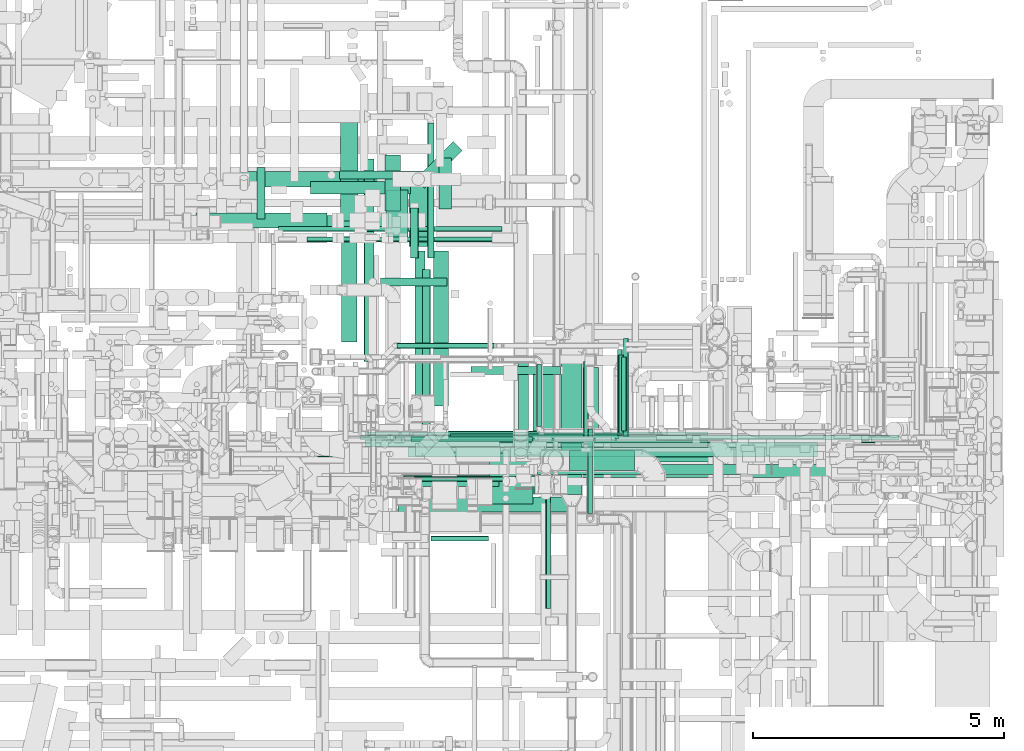
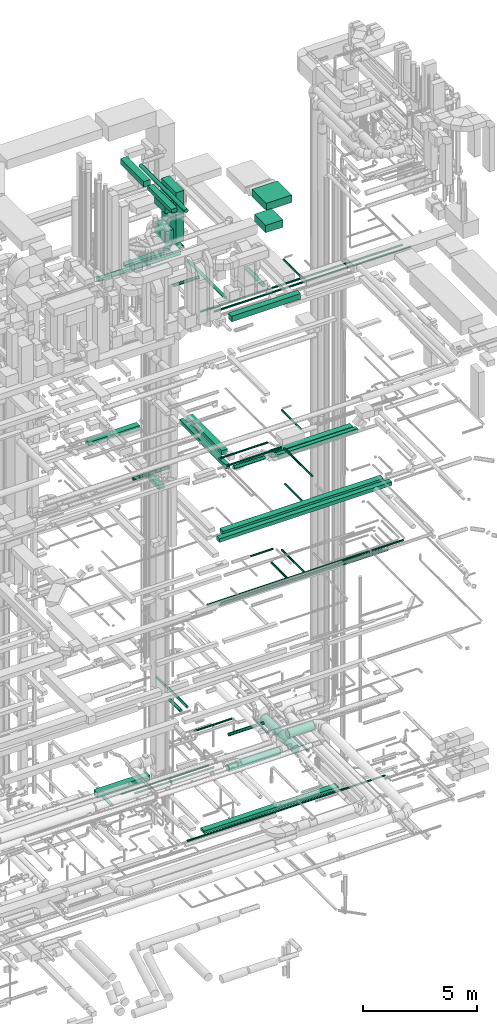
# One storey, part 62 of 337: 56 flow segments.
"""IFC2X3 building model written with IfcOpenShell, lengths in millimetres."""

from ifc_helpers import new_model, entity, si_unit, converted_unit, derived_unit, direction, frame, origin, origin_2d_with_axis, place, context, subcontext, project, spatial, rectangle, circle, extrude, type_object, element, save


model = new_model("IFC2X3")

# Units and contexts
model_context = context("Model", 3, precision=0.01, world=origin(), true_north=direction((6.12303176911189e-17, 1.0)))
body_context = subcontext(model_context, "Body", "Model", "MODEL_VIEW")
ifc_project = project(units=[si_unit("LENGTHUNIT", "METRE", prefix="MILLI"), si_unit("AREAUNIT", "SQUARE_METRE"), si_unit("VOLUMEUNIT", "CUBIC_METRE"), converted_unit("PLANEANGLEUNIT", "DEGREE", entity("IfcRatioMeasure", 0.0174532925199433), si_unit("PLANEANGLEUNIT", "RADIAN"), dimensions=[0, 0, 0, 0, 0, 0, 0]), si_unit("MASSUNIT", "GRAM", prefix="KILO"), derived_unit("MASSDENSITYUNIT", [(si_unit("MASSUNIT", "GRAM", prefix="KILO"), 1), (si_unit("LENGTHUNIT", "METRE"), -3)]), derived_unit("MOMENTOFINERTIAUNIT", [(si_unit("LENGTHUNIT", "METRE"), 4)]), si_unit("TIMEUNIT", "SECOND"), si_unit("FREQUENCYUNIT", "HERTZ"), si_unit("THERMODYNAMICTEMPERATUREUNIT", "DEGREE_CELSIUS"), derived_unit("THERMALTRANSMITTANCEUNIT", [(si_unit("MASSUNIT", "GRAM", prefix="KILO"), 1), (si_unit("THERMODYNAMICTEMPERATUREUNIT", "KELVIN"), -1), (si_unit("TIMEUNIT", "SECOND"), -3)]), derived_unit("VOLUMETRICFLOWRATEUNIT", [(si_unit("LENGTHUNIT", "METRE"), 3), (si_unit("TIMEUNIT", "SECOND"), -1)]), derived_unit("MASSFLOWRATEUNIT", [(si_unit("MASSUNIT", "GRAM", prefix="KILO"), 1), (si_unit("TIMEUNIT", "SECOND"), -1)]), derived_unit("ROTATIONALFREQUENCYUNIT", [(si_unit("TIMEUNIT", "SECOND"), -1)]), si_unit("ELECTRICCURRENTUNIT", "AMPERE"), si_unit("ELECTRICVOLTAGEUNIT", "VOLT"), si_unit("POWERUNIT", "WATT"), si_unit("FORCEUNIT", "NEWTON", prefix="KILO"), si_unit("ILLUMINANCEUNIT", "LUX"), si_unit("LUMINOUSFLUXUNIT", "LUMEN"), si_unit("LUMINOUSINTENSITYUNIT", "CANDELA"), derived_unit("USERDEFINED", [(si_unit("MASSUNIT", "GRAM", prefix="KILO"), -1), (si_unit("LENGTHUNIT", "METRE"), -2), (si_unit("TIMEUNIT", "SECOND"), 3), (si_unit("LUMINOUSFLUXUNIT", "LUMEN"), 1)]), derived_unit("LINEARVELOCITYUNIT", [(si_unit("LENGTHUNIT", "METRE"), 1), (si_unit("TIMEUNIT", "SECOND"), -1)]), si_unit("PRESSUREUNIT", "PASCAL"), derived_unit("USERDEFINED", [(si_unit("LENGTHUNIT", "METRE"), -2), (si_unit("MASSUNIT", "GRAM", prefix="KILO"), 1), (si_unit("TIMEUNIT", "SECOND"), -2)]), derived_unit("LINEARFORCEUNIT", [(si_unit("MASSUNIT", "GRAM", prefix="KILO"), 1), (si_unit("LENGTHUNIT", "METRE"), 1), (si_unit("TIMEUNIT", "SECOND"), -2), (si_unit("LENGTHUNIT", "METRE"), -1)]), derived_unit("PLANARFORCEUNIT", [(si_unit("MASSUNIT", "GRAM", prefix="KILO"), 1), (si_unit("LENGTHUNIT", "METRE"), 1), (si_unit("TIMEUNIT", "SECOND"), -2), (si_unit("LENGTHUNIT", "METRE"), -2)])], contexts=[model_context])

# Site, building, storey
site_placement = place(None, origin())
site = spatial("IfcSite", under=ifc_project, at=site_placement, CompositionType="ELEMENT")
building_placement = place(site_placement, origin())
building = spatial("IfcBuilding", under=site, at=building_placement, CompositionType="ELEMENT")
storey_placement = place(building_placement, origin())
storey = spatial("IfcBuildingStorey", under=building, at=storey_placement, CompositionType="ELEMENT", Elevation=0.0)

# Flow segments
duct_segment_type_1 = type_object("IfcDuctSegmentType", PredefinedType="NOTDEFINED")
flow_segment_1_placement = place(storey_placement, frame((58090.67, 15198.96, -1000.0)))
element("IfcFlowSegment", 1, at=flow_segment_1_placement, inside=storey, type_object=duct_segment_type_1, context=body_context, shape_type="SweptSolid", body=[
    extrude(rectangle(XDim=2690.26260986296, YDim=300.000000000001, at=origin_2d_with_axis()), frame((1345.13, 150.0, 0.0)), (0.0, 0.0, 1.0), 300.0),
])
flow_segment_2_placement = place(storey_placement, frame((60535.27, 10024.06, -625.0)))
element("IfcFlowSegment", 2, at=flow_segment_2_placement, inside=storey, type_object=duct_segment_type_1, context=body_context, shape_type="SweptSolid", body=[
    extrude(rectangle(XDim=6820.00000000004, YDim=300.000000000001, at=origin_2d_with_axis()), frame((3410.0, 150.0, 0.0)), (0.0, 0.0, 1.0), 150.0),
])
flow_segment_3_placement = place(storey_placement, frame((61388.43, 9824.99, 15250.0)))
element("IfcFlowSegment", 3, at=flow_segment_3_placement, inside=storey, type_object=duct_segment_type_1, context=body_context, shape_type="SweptSolid", body=[
    extrude(rectangle(XDim=8149.51466795696, YDim=300.0, at=origin_2d_with_axis()), frame((4074.76, 150.0, 0.0), z_axis=(0.0, 0.0, 1.0), x_axis=(-1.0, -7.91811769597253e-08, 0.0)), (0.0, 0.0, 1.0), 199.999999999998),
])
flow_segment_4_placement = place(storey_placement, frame((60962.19, 9419.34, 15250.0)))
element("IfcFlowSegment", 4, at=flow_segment_4_placement, inside=storey, type_object=duct_segment_type_1, context=body_context, shape_type="SweptSolid", body=[
    extrude(rectangle(XDim=8774.39136081539, YDim=249.999999999999, at=origin_2d_with_axis()), frame((4387.2, 125.0, 0.0)), (0.0, 0.0, 1.0), 200.000000000002),
])
flow_segment_5_placement = place(storey_placement, frame((63795.0, 9724.07, 18610.0)))
element("IfcFlowSegment", 5, at=flow_segment_5_placement, inside=storey, type_object=duct_segment_type_1, context=body_context, shape_type="SweptSolid", body=[
    extrude(rectangle(XDim=4147.57256313354, YDim=300.000000000001, at=origin_2d_with_axis()), frame((2073.79, 150.0, 0.0), z_axis=(0.0, 0.0, 1.0), x_axis=(-1.0, 0.0, 0.0)), (0.0, 0.0, 1.0), 249.999999999999),
])
flow_segment_6_placement = place(storey_placement, frame((61894.65, 10834.23, 18750.0)))
element("IfcFlowSegment", 6, at=flow_segment_6_placement, inside=storey, type_object=duct_segment_type_1, context=body_context, shape_type="SweptSolid", body=[
    extrude(rectangle(XDim=3091.09127034734, YDim=300.000000000001, at=origin_2d_with_axis()), frame((150.0, 1545.55, 0.0), z_axis=(0.0, 0.0, 1.0), x_axis=(0.0, -1.0, 0.0)), (0.0, 0.0, 1.0), 249.999999999999),
])
flow_segment_7_placement = place(storey_placement, frame((61530.06, 9825.53, 18750.0)))
element("IfcFlowSegment", 7, at=flow_segment_7_placement, inside=storey, type_object=duct_segment_type_1, context=body_context, shape_type="SweptSolid", body=[
    extrude(rectangle(XDim=4100.00000000001, YDim=199.999999999998, at=origin_2d_with_axis()), frame((100.0, 2050.0, 0.0), z_axis=(0.0, 0.0, 1.0), x_axis=(0.0, -1.0, 0.0)), (0.0, 0.0, 1.0), 199.999999999998),
])
flow_segment_8_placement = place(storey_placement, frame((63970.91, 9475.53, 18670.0)))
element("IfcFlowSegment", 8, at=flow_segment_8_placement, inside=storey, type_object=duct_segment_type_1, context=body_context, shape_type="SweptSolid", body=[
    extrude(rectangle(XDim=4066.47664722536, YDim=200.0, at=origin_2d_with_axis()), frame((2033.24, 100.0, 0.0), z_axis=(0.0, 0.0, 1.0), x_axis=(-1.0, 0.0, 0.0)), (0.0, 0.0, 1.0), 200.000000000002),
])
flow_segment_9_placement = place(storey_placement, frame((57176.47, 14375.32, 18750.0)))
element("IfcFlowSegment", 9, at=flow_segment_9_placement, inside=storey, type_object=duct_segment_type_1, context=body_context, shape_type="SweptSolid", body=[
    extrude(rectangle(XDim=2601.95863933924, YDim=300.000000000001, at=origin_2d_with_axis()), frame((1300.98, 150.0, 0.0), z_axis=(0.0, 0.0, 1.0), x_axis=(-1.0, 0.0, 0.0)), (0.0, 0.0, 1.0), 200.000000000002),
])
flow_segment_10_placement = place(storey_placement, frame((60938.43, 14718.5, 14875.0)))
element("IfcFlowSegment", 10, at=flow_segment_10_placement, inside=storey, type_object=duct_segment_type_1, context=body_context, shape_type="SweptSolid", body=[
    extrude(rectangle(XDim=1111.49873218096, YDim=300.000000000001, at=origin_2d_with_axis()), frame((150.0, 555.75, 0.0), z_axis=(0.0, 0.0, 1.0), x_axis=(0.0, 1.0, 0.0)), (0.0, 0.0, 1.0), 199.999999999998),
])
flow_segment_11_placement = place(storey_placement, frame((61191.73, 8725.02, 27450.0)))
element("IfcFlowSegment", 11, at=flow_segment_11_placement, inside=storey, type_object=duct_segment_type_1, context=body_context, shape_type="SweptSolid", body=[
    extrude(rectangle(XDim=3500.00000000001, YDim=300.0, at=origin_2d_with_axis()), frame((1750.0, 150.0, 0.0)), (0.0, 0.0, 1.0), 300.000000000001),
])
flow_segment_12_placement = place(storey_placement, frame((59450.82, 15052.02, 27135.0)))
element("IfcFlowSegment", 12, at=flow_segment_12_placement, inside=storey, type_object=duct_segment_type_1, context=body_context, shape_type="SweptSolid", body=[
    extrude(rectangle(XDim=1986.09127034739, YDim=249.999999999999, at=origin_2d_with_axis()), frame((993.05, 125.0, 0.0)), (0.0, 0.0, 1.0), 150.000000000001),
])
flow_segment_13_placement = place(storey_placement, frame((61542.98, 15169.18, 27135.0)))
element("IfcFlowSegment", 13, at=flow_segment_13_placement, inside=storey, type_object=duct_segment_type_1, context=body_context, shape_type="SweptSolid", body=[
    extrude(rectangle(XDim=1061.47186257612, YDim=249.999999999997, at=origin_2d_with_axis()), frame((463.68, 463.68, 0.0), z_axis=(0.0, 0.0, 1.0), x_axis=(0.70710678118655, 0.707106781186545, 0.0)), (0.0, 0.0, 1.0), 150.000000000001),
])
duct_segment_type_2 = type_object("IfcDuctSegmentType", PredefinedType="NOTDEFINED")
flow_segment_14_placement = place(storey_placement, frame((59587.7, 9821.97, -631.6)))
element("IfcFlowSegment", 14, at=flow_segment_14_placement, inside=storey, type_object=duct_segment_type_2, context=body_context, shape_type="SweptSolid", body=[
    extrude(circle(Radius=50.0, at=origin_2d_with_axis()), frame((0.0, 51.6, 51.6), z_axis=(1.0, 0.0, 0.0), x_axis=(0.0, -1.0, 0.0)), (0.0, 0.0, 1.0), 10064.6284934809),
])
flow_segment_15_placement = place(storey_placement, frame((58816.63, 14312.03, -571.6)))
element("IfcFlowSegment", 15, at=flow_segment_15_placement, inside=storey, type_object=duct_segment_type_2, context=body_context, shape_type="SweptSolid", body=[
    extrude(circle(Radius=50.0, at=origin_2d_with_axis()), frame((0.0, 51.6, 51.6), z_axis=(1.0, 0.0, 0.0), x_axis=(0.0, -1.0, 0.0)), (0.0, 0.0, 1.0), 4447.54223999996),
])
flow_segment_16_placement = place(storey_placement, frame((59378.6, 14101.68, -601.6)))
element("IfcFlowSegment", 16, at=flow_segment_16_placement, inside=storey, type_object=duct_segment_type_2, context=body_context, shape_type="SweptSolid", body=[
    extrude(circle(Radius=50.0, at=origin_2d_with_axis()), frame((0.0, 51.6, 51.6), z_axis=(1.0, 0.0, 0.0), x_axis=(0.0, 1.0, 0.0)), (0.0, 0.0, 1.0), 4035.59833488559),
])
flow_segment_17_placement = place(storey_placement, frame((58382.55, 14558.39, -1181.6)))
element("IfcFlowSegment", 17, at=flow_segment_17_placement, inside=storey, type_object=duct_segment_type_2, context=body_context, shape_type="SweptSolid", body=[
    extrude(circle(Radius=80.0, at=origin_2d_with_axis()), frame((81.6, 0.0, 81.6), z_axis=(0.0, 1.0, 0.0), x_axis=(1.0, 0.0, 0.0)), (0.0, 0.0, 1.0), 1023.58730893046),
])
flow_segment_18_placement = place(storey_placement, frame((60747.71, 10104.0, 11468.4)))
element("IfcFlowSegment", 18, at=flow_segment_18_placement, inside=storey, type_object=duct_segment_type_2, context=body_context, shape_type="SweptSolid", body=[
    extrude(circle(Radius=50.0, at=origin_2d_with_axis()), frame((0.0, 51.6, 51.6), z_axis=(1.0, 0.0, 0.0), x_axis=(0.0, -1.0, 0.0)), (0.0, 0.0, 1.0), 10000.0),
])
flow_segment_19_placement = place(storey_placement, frame((65676.11, 10225.6, 11468.4)))
element("IfcFlowSegment", 19, at=flow_segment_19_placement, inside=storey, type_object=duct_segment_type_2, context=body_context, shape_type="SweptSolid", body=[
    extrude(circle(Radius=50.0, at=origin_2d_with_axis()), frame((51.6, 0.0, 51.6), z_axis=(0.0, 1.0, 0.0), x_axis=(1.0, 0.0, 0.0)), (0.0, 0.0, 1.0), 1953.13763475681),
])
flow_segment_20_placement = place(storey_placement, frame((61368.7, 10104.0, 11228.4)))
element("IfcFlowSegment", 20, at=flow_segment_20_placement, inside=storey, type_object=duct_segment_type_2, context=body_context, shape_type="SweptSolid", body=[
    extrude(circle(Radius=50.0, at=origin_2d_with_axis()), frame((0.0, 51.6, 51.6), z_axis=(1.0, 0.0, 0.0), x_axis=(0.0, 1.0, 0.0)), (0.0, 0.0, 1.0), 8598.57862238153),
])
flow_segment_21_placement = place(storey_placement, frame((61293.27, 9096.79, 2920.9)))
element("IfcFlowSegment", 21, at=flow_segment_21_placement, inside=storey, type_object=duct_segment_type_2, context=body_context, shape_type="SweptSolid", body=[
    extrude(circle(Radius=177.5, at=origin_2d_with_axis()), frame((0.0, 179.1, 179.1), z_axis=(1.0, 0.0, 0.0), x_axis=(0.0, -1.0, 0.0)), (0.0, 0.0, 1.0), 2623.20810251035),
])
flow_segment_22_placement = place(storey_placement, frame((61173.7, 11984.54, 3398.4)))
element("IfcFlowSegment", 22, at=flow_segment_22_placement, inside=storey, type_object=duct_segment_type_2, context=body_context, shape_type="SweptSolid", body=[
    extrude(circle(Radius=50.0, at=origin_2d_with_axis()), frame((0.0, 51.6, 51.6), z_axis=(1.0, 0.0, 0.0), x_axis=(0.0, -1.0, 0.0)), (0.0, 0.0, 1.0), 1932.1572875254),
])
flow_segment_23_placement = place(storey_placement, frame((61530.06, 10234.73, 11228.4)))
element("IfcFlowSegment", 23, at=flow_segment_23_placement, inside=storey, type_object=duct_segment_type_2, context=body_context, shape_type="SweptSolid", body=[
    extrude(circle(Radius=50.0, at=origin_2d_with_axis()), frame((0.0, 51.6, 51.6), z_axis=(1.0, 0.0, 0.0), x_axis=(0.0, 1.0, 0.0)), (0.0, 0.0, 1.0), 8235.71998021879),
])
flow_segment_24_placement = place(storey_placement, frame((61455.06, 10127.45, 19108.4)))
element("IfcFlowSegment", 24, at=flow_segment_24_placement, inside=storey, type_object=duct_segment_type_2, context=body_context, shape_type="SweptSolid", body=[
    extrude(circle(Radius=50.0, at=origin_2d_with_axis()), frame((0.0, 51.6, 51.6), z_axis=(1.0, 0.0, 0.0), x_axis=(0.0, 1.0, 0.0)), (0.0, 0.0, 1.0), 2414.57864376269),
])
flow_segment_25_placement = place(storey_placement, frame((65553.41, 10249.05, 19148.4)))
element("IfcFlowSegment", 25, at=flow_segment_25_placement, inside=storey, type_object=duct_segment_type_2, context=body_context, shape_type="SweptSolid", body=[
    extrude(circle(Radius=50.0, at=origin_2d_with_axis()), frame((51.6, 0.0, 51.6), z_axis=(0.0, 1.0, 0.0), x_axis=(1.0, 0.0, 0.0)), (0.0, 0.0, 1.0), 1716.87499999997),
])
flow_segment_26_placement = place(storey_placement, frame((61294.84, 9333.52, 19223.4)))
element("IfcFlowSegment", 26, at=flow_segment_26_placement, inside=storey, type_object=duct_segment_type_2, context=body_context, shape_type="SweptSolid", body=[
    extrude(circle(Radius=50.0, at=origin_2d_with_axis()), frame((0.0, 51.6, 51.6), z_axis=(1.0, 0.0, 0.0), x_axis=(0.0, -1.0, 0.0)), (0.0, 0.0, 1.0), 2785.00000000022),
])
flow_segment_27_placement = place(storey_placement, frame((64128.24, 6808.61, 19223.4)))
element("IfcFlowSegment", 27, at=flow_segment_27_placement, inside=storey, type_object=duct_segment_type_2, context=body_context, shape_type="SweptSolid", body=[
    extrude(circle(Radius=50.0, at=origin_2d_with_axis()), frame((51.6, 0.0, 51.6), z_axis=(0.0, 1.0, 0.0), x_axis=(-1.0, 0.0, 0.0)), (0.0, 0.0, 1.0), 2476.51008030517),
])
flow_segment_28_placement = place(storey_placement, frame((64880.89, 10128.22, 11348.4)))
element("IfcFlowSegment", 28, at=flow_segment_28_placement, inside=storey, type_object=duct_segment_type_2, context=body_context, shape_type="SweptSolid", body=[
    extrude(circle(Radius=50.0, at=origin_2d_with_axis()), frame((51.6, 0.0, 51.6), z_axis=(0.0, 1.0, 0.0), x_axis=(1.0, 0.0, 0.0)), (0.0, 0.0, 1.0), 1596.5871475169),
])
flow_segment_29_placement = place(storey_placement, frame((61850.56, 8148.04, 14898.4)))
element("IfcFlowSegment", 29, at=flow_segment_29_placement, inside=storey, type_object=duct_segment_type_2, context=body_context, shape_type="SweptSolid", body=[
    extrude(circle(Radius=50.0, at=origin_2d_with_axis()), frame((0.0, 51.6, 51.6), z_axis=(1.0, 0.0, 0.0), x_axis=(0.0, -1.0, 0.0)), (0.0, 0.0, 1.0), 1140.0),
])
flow_segment_30_placement = place(storey_placement, frame((62234.96, 10188.75, 15248.4)))
element("IfcFlowSegment", 30, at=flow_segment_30_placement, inside=storey, type_object=duct_segment_type_2, context=body_context, shape_type="SweptSolid", body=[
    extrude(circle(Radius=50.0, at=origin_2d_with_axis()), frame((0.0, 51.6, 51.6), z_axis=(1.0, 0.0, 0.0), x_axis=(0.0, -1.0, 0.0)), (0.0, 0.0, 1.0), 3350.00000000001),
])
flow_segment_31_placement = place(storey_placement, frame((65633.37, 10340.34, 15248.4)))
element("IfcFlowSegment", 31, at=flow_segment_31_placement, inside=storey, type_object=duct_segment_type_2, context=body_context, shape_type="SweptSolid", body=[
    extrude(circle(Radius=50.0, at=origin_2d_with_axis()), frame((51.6, 0.0, 51.6), z_axis=(0.0, 1.0, 0.0), x_axis=(1.0, 0.0, 0.0)), (0.0, 0.0, 1.0), 1473.85870500009),
])
flow_segment_32_placement = place(storey_placement, frame((61626.51, 9236.98, 18998.4)))
element("IfcFlowSegment", 32, at=flow_segment_32_placement, inside=storey, type_object=duct_segment_type_2, context=body_context, shape_type="SweptSolid", body=[
    extrude(circle(Radius=100.0, at=origin_2d_with_axis()), frame((0.0, 101.6, 101.6), z_axis=(1.0, 0.0, 0.0), x_axis=(0.0, 1.0, 0.0)), (0.0, 0.0, 1.0), 1574.35791045205),
])
flow_segment_33_placement = place(storey_placement, frame((60029.3, 15348.41, 15268.4)))
element("IfcFlowSegment", 33, at=flow_segment_33_placement, inside=storey, type_object=duct_segment_type_2, context=body_context, shape_type="SweptSolid", body=[
    extrude(circle(Radius=80.0, at=origin_2d_with_axis()), frame((0.0, 81.6, 81.6), z_axis=(1.0, 0.0, 0.0), x_axis=(0.0, 1.0, 0.0)), (0.0, 0.0, 1.0), 1838.62251742501),
])
flow_segment_34_placement = place(storey_placement, frame((60848.85, 13224.03, 26668.4)))
element("IfcFlowSegment", 34, at=flow_segment_34_placement, inside=storey, type_object=duct_segment_type_2, context=body_context, shape_type="SweptSolid", body=[
    extrude(circle(Radius=80.0, at=origin_2d_with_axis()), frame((0.0, 81.6, 81.6), z_axis=(1.0, 0.0, 0.0), x_axis=(0.0, -1.0, 0.0)), (0.0, 0.0, 1.0), 1320.00000000006),
])
flow_segment_35_placement = place(storey_placement, frame((57686.13, 14378.71, 27323.4)))
element("IfcFlowSegment", 35, at=flow_segment_35_placement, inside=storey, type_object=duct_segment_type_2, context=body_context, shape_type="SweptSolid", body=[
    extrude(circle(Radius=125.0, at=origin_2d_with_axis()), frame((0.0, 126.6, 126.6), z_axis=(1.0, 0.0, 0.0), x_axis=(0.0, 1.0, 0.0)), (0.0, 0.0, 1.0), 4197.86042472946),
])
flow_segment_36_placement = place(storey_placement, frame((62007.4, 14755.3, 27323.4)))
element("IfcFlowSegment", 36, at=flow_segment_36_placement, inside=storey, type_object=duct_segment_type_2, context=body_context, shape_type="SweptSolid", body=[
    extrude(circle(Radius=125.0, at=origin_2d_with_axis()), frame((126.6, 0.0, 126.6), z_axis=(0.0, 1.0, 0.0), x_axis=(1.0, 0.0, 0.0)), (0.0, 0.0, 1.0), 1015.0),
])
flow_segment_37_placement = place(storey_placement, frame((63588.42, 10252.41, 27523.4)))
element("IfcFlowSegment", 37, at=flow_segment_37_placement, inside=storey, type_object=duct_segment_type_2, context=body_context, shape_type="SweptSolid", body=[
    extrude(circle(Radius=100.0, at=origin_2d_with_axis()), frame((101.6, 0.0, 101.6), z_axis=(0.0, 1.0, 0.0), x_axis=(-1.0, 0.0, 0.0)), (0.0, 0.0, 1.0), 1465.00000000003),
])
flow_segment_38_placement = place(storey_placement, frame((61673.99, 10252.41, 27543.4)))
element("IfcFlowSegment", 38, at=flow_segment_38_placement, inside=storey, type_object=duct_segment_type_2, context=body_context, shape_type="SweptSolid", body=[
    extrude(circle(Radius=80.0, at=origin_2d_with_axis()), frame((81.6, 0.0, 81.6), z_axis=(0.0, 1.0, 0.0), x_axis=(1.0, 0.0, 0.0)), (0.0, 0.0, 1.0), 3298.70057685091),
])
flow_segment_39_placement = place(storey_placement, frame((60449.74, 10158.39, 27308.4)))
element("IfcFlowSegment", 39, at=flow_segment_39_placement, inside=storey, type_object=duct_segment_type_2, context=body_context, shape_type="SweptSolid", body=[
    extrude(circle(Radius=50.0, at=origin_2d_with_axis()), frame((0.0, 51.6, 51.6), z_axis=(1.0, 0.0, 0.0), x_axis=(0.0, 1.0, 0.0)), (0.0, 0.0, 1.0), 10271.1269837221),
])
flow_segment_40_placement = place(storey_placement, frame((65578.03, 10279.98, 27308.4)))
element("IfcFlowSegment", 40, at=flow_segment_40_placement, inside=storey, type_object=duct_segment_type_2, context=body_context, shape_type="SweptSolid", body=[
    extrude(circle(Radius=50.0, at=origin_2d_with_axis()), frame((51.6, 0.0, 51.6), z_axis=(0.0, 1.0, 0.0), x_axis=(1.0, 0.0, 0.0)), (0.0, 0.0, 1.0), 1574.40000000001),
])
flow_segment_41_placement = place(storey_placement, frame((64446.67, 9074.91, 2848.4)))
element("IfcFlowSegment", 41, at=flow_segment_41_placement, inside=storey, type_object=duct_segment_type_2, context=body_context, shape_type="SweptSolid", body=[
    extrude(circle(Radius=200.0, at=origin_2d_with_axis()), frame((201.6, 0.0, 201.6), z_axis=(0.0, 1.0, 0.0), x_axis=(1.0, 0.0, 0.0)), (0.0, 0.0, 1.0), 2775.00000000001),
])
flow_segment_42_placement = place(storey_placement, frame((62643.27, 11461.04, 2968.4)))
element("IfcFlowSegment", 42, at=flow_segment_42_placement, inside=storey, type_object=duct_segment_type_2, context=body_context, shape_type="SweptSolid", body=[
    extrude(circle(Radius=80.0, at=origin_2d_with_axis()), frame((0.0, 81.6, 81.6), z_axis=(1.0, 0.0, 0.0), x_axis=(0.0, 1.0, 0.0)), (0.0, 0.0, 1.0), 1785.00000000004),
])
flow_segment_43_placement = place(storey_placement, frame((63950.59, 10424.99, 3298.4)))
element("IfcFlowSegment", 43, at=flow_segment_43_placement, inside=storey, type_object=duct_segment_type_2, context=body_context, shape_type="SweptSolid", body=[
    extrude(circle(Radius=50.0, at=origin_2d_with_axis()), frame((51.6, 0.0, 51.6), z_axis=(0.0, 1.0, 0.0), x_axis=(-1.0, 0.0, 0.0)), (0.0, 0.0, 1.0), 1237.60000000001),
])
flow_segment_44_placement = place(storey_placement, frame((60518.44, 11724.89, 31698.4)))
element("IfcFlowSegment", 44, at=flow_segment_44_placement, inside=storey, type_object=duct_segment_type_2, context=body_context, shape_type="SweptSolid", body=[
    extrude(circle(Radius=100.0, at=origin_2d_with_axis()), frame((101.6, 0.0, 101.6), z_axis=(0.0, 1.0, 0.0), x_axis=(1.0, 0.0, 0.0)), (0.0, 0.0, 1.0), 4024.71103541324),
])
flow_segment_45_placement = place(storey_placement, frame((61141.92, 10158.38, 27068.4)))
element("IfcFlowSegment", 45, at=flow_segment_45_placement, inside=storey, type_object=duct_segment_type_2, context=body_context, shape_type="SweptSolid", body=[
    extrude(circle(Radius=50.0, at=origin_2d_with_axis()), frame((0.0, 51.6, 51.6), z_axis=(1.0, 0.0, 0.0), x_axis=(0.0, -1.0, 0.0)), (0.0, 0.0, 1.0), 10017.1572875254),
])
flow_segment_46_placement = place(storey_placement, frame((64605.16, 9548.4, 3298.4)))
element("IfcFlowSegment", 46, at=flow_segment_46_placement, inside=storey, type_object=duct_segment_type_2, context=body_context, shape_type="SweptSolid", body=[
    extrude(circle(Radius=200.0, at=origin_2d_with_axis()), frame((0.0, 201.6, 201.6), z_axis=(1.0, 0.0, 0.0), x_axis=(0.0, 1.0, 0.0)), (0.0, 0.0, 1.0), 1293.81173910657),
])
flow_segment_47_placement = place(storey_placement, frame((64965.15, 8696.67, 3048.4)))
element("IfcFlowSegment", 47, at=flow_segment_47_placement, inside=storey, type_object=duct_segment_type_2, context=body_context, shape_type="SweptSolid", body=[
    extrude(circle(Radius=50.0, at=origin_2d_with_axis()), frame((51.6, 0.0, 51.6), z_axis=(0.0, 1.0, 0.0), x_axis=(-1.0, 0.0, 0.0)), (0.0, 0.0, 1.0), 1682.46889627103),
])
flow_segment_48_placement = place(storey_placement, frame((61437.29, 13778.74, 3298.4)))
element("IfcFlowSegment", 48, at=flow_segment_48_placement, inside=storey, type_object=duct_segment_type_2, context=body_context, shape_type="SweptSolid", body=[
    extrude(circle(Radius=80.0, at=origin_2d_with_axis()), frame((81.6, 0.0, 81.6), z_axis=(0.0, 1.0, 0.0), x_axis=(-1.0, 0.0, 0.0)), (0.0, 0.0, 1.0), 999.999999999911),
])
flow_segment_49_placement = place(storey_placement, frame((61782.96, 13778.74, 3385.9)))
element("IfcFlowSegment", 49, at=flow_segment_49_placement, inside=storey, type_object=duct_segment_type_2, context=body_context, shape_type="SweptSolid", body=[
    extrude(circle(Radius=62.5, at=origin_2d_with_axis()), frame((64.1, 0.0, 64.1), z_axis=(0.0, 1.0, 0.0), x_axis=(-1.0, 0.0, 0.0)), (0.0, 0.0, 1.0), 2692.50363942774),
])
duct_segment_type_3 = type_object("IfcDuctSegmentType", PredefinedType="NOTDEFINED")
flow_segment_50_placement = place(storey_placement, frame((60047.93, 14514.42, 31575.0)))
element("IfcFlowSegment", 50, at=flow_segment_50_placement, inside=storey, type_object=duct_segment_type_3, context=body_context, shape_type="SweptSolid", body=[
    extrude(rectangle(XDim=2051.03876673876, YDim=349.999999999998, at=origin_2d_with_axis()), frame((175.0, 1025.52, 0.0), z_axis=(0.0, 0.0, 1.0), x_axis=(0.0, 1.0, 0.0)), (0.0, 0.0, 1.0), 300.000000000001),
])
flow_segment_51_placement = place(storey_placement, frame((60072.93, 12114.2, 31625.0)))
element("IfcFlowSegment", 51, at=flow_segment_51_placement, inside=storey, type_object=duct_segment_type_3, context=body_context, shape_type="SweptSolid", body=[
    extrude(rectangle(XDim=2100.22028783241, YDim=300.000000000001, at=origin_2d_with_axis()), frame((150.0, 1050.11, 0.0), z_axis=(0.0, 0.0, 1.0), x_axis=(0.0, 1.0, 0.0)), (0.0, 0.0, 1.0), 199.999999999998),
])
flow_segment_52_placement = place(storey_placement, frame((60963.69, 14195.6, 30026.0)))
element("IfcFlowSegment", 52, at=flow_segment_52_placement, inside=storey, type_object=duct_segment_type_3, context=body_context, shape_type="SweptSolid", body=[
    extrude(rectangle(XDim=429.479090722235, YDim=937.999999999999, at=origin_2d_with_axis()), frame((214.74, 469.0, 0.0), z_axis=(0.0, 0.0, 1.0), x_axis=(-1.0, 0.0, 0.0)), (0.0, 0.0, 1.0), 617.999999999998),
])
flow_segment_53_placement = place(storey_placement, frame((61413.17, 14014.6, 28390.0)))
element("IfcFlowSegment", 53, at=flow_segment_53_placement, inside=storey, type_object=duct_segment_type_3, context=body_context, shape_type="SweptSolid", body=[
    extrude(rectangle(XDim=399.999999999996, YDim=1300.0, at=origin_2d_with_axis()), frame((200.0, 650.0, 0.0), z_axis=(0.0, 0.0, 1.0), x_axis=(-1.0, 0.0, 0.0)), (0.0, 0.0, 1.0), 2709.99997500007),
])
flow_segment_54_placement = place(storey_placement, frame((63010.11, 8888.29, 31500.0)))
element("IfcFlowSegment", 54, at=flow_segment_54_placement, inside=storey, type_object=duct_segment_type_3, context=body_context, shape_type="SweptSolid", body=[
    extrude(rectangle(XDim=869.87221024618, YDim=1000.0, at=origin_2d_with_axis()), frame((434.94, 500.0, 0.0), z_axis=(0.0, 0.0, 1.0), x_axis=(-1.0, 0.0, 0.0)), (0.0, 0.0, 1.0), 399.999999999996),
])
flow_segment_55_placement = place(storey_placement, frame((60963.69, 14195.6, 28426.0)))
element("IfcFlowSegment", 55, at=flow_segment_55_placement, inside=storey, type_object=duct_segment_type_3, context=body_context, shape_type="SweptSolid", body=[
    extrude(rectangle(XDim=429.479090722235, YDim=937.999999999999, at=origin_2d_with_axis()), frame((214.74, 469.0, 0.0), z_axis=(0.0, 0.0, 1.0), x_axis=(-1.0, 0.0, 0.0)), (0.0, 0.0, 1.0), 617.999999999998),
])
flow_segment_56_placement = place(storey_placement, frame((63879.98, 10338.29, 31500.0)))
element("IfcFlowSegment", 56, at=flow_segment_56_placement, inside=storey, type_object=duct_segment_type_3, context=body_context, shape_type="SweptSolid", body=[
    extrude(rectangle(XDim=1261.90871733208, YDim=1300.0, at=origin_2d_with_axis()), frame((650.0, 630.95, 0.0), z_axis=(0.0, 0.0, 1.0), x_axis=(0.0, 1.0, 0.0)), (0.0, 0.0, 1.0), 400.000000000004),
])

save(model, "model.ifc")
